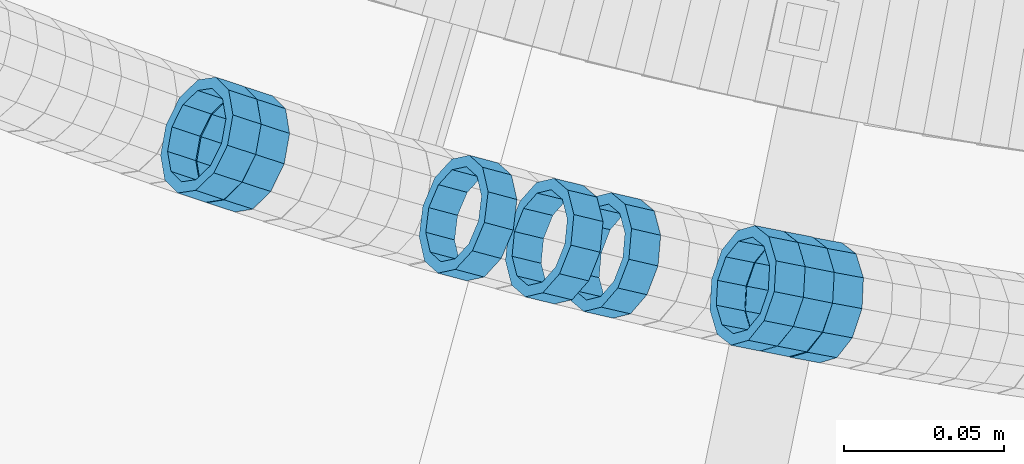
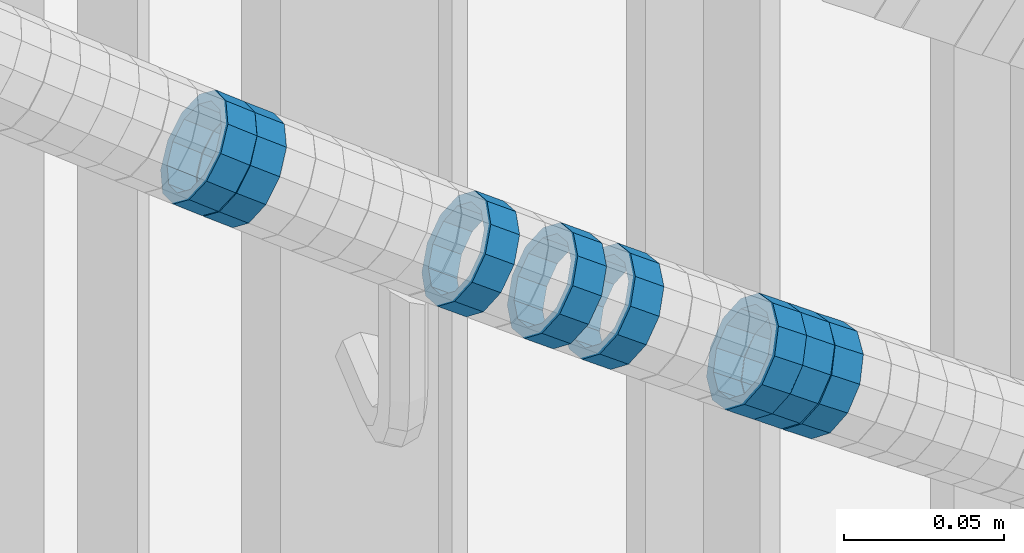
# One storey, part 687 of 975: 8 members.
"""IFC2X3 building model written with IfcOpenShell, lengths in millimetres."""

from ifc_helpers import new_model, si_unit, frame, origin_with_axes, place, context, subcontext, project, spatial, faceted_brep, material, type_object, element, save


model = new_model("IFC2X3")

# Units and contexts
model_context = context("Model", 3, precision=1e-05, world=origin_with_axes())
body_context = subcontext(model_context, "Body", "Model", "MODEL_VIEW")
ifc_project = project(units=[si_unit("LENGTHUNIT", "METRE", prefix="MILLI"), si_unit("AREAUNIT", "SQUARE_METRE"), si_unit("VOLUMEUNIT", "CUBIC_METRE"), si_unit("MASSUNIT", "GRAM", prefix="KILO"), si_unit("TIMEUNIT", "SECOND"), si_unit("PLANEANGLEUNIT", "RADIAN"), si_unit("SOLIDANGLEUNIT", "STERADIAN"), si_unit("THERMODYNAMICTEMPERATUREUNIT", "DEGREE_CELSIUS"), si_unit("LUMINOUSINTENSITYUNIT", "LUMEN")], contexts=[model_context])

# Site, building, storey
site_placement = place(None, origin_with_axes())
site = spatial("IfcSite", under=ifc_project, at=site_placement, CompositionType="ELEMENT")
building_placement = place(site_placement, origin_with_axes())
building = spatial("IfcBuilding", under=site, at=building_placement, Name="Undefined", CompositionType="ELEMENT")
storey_placement = place(building_placement, origin_with_axes())
storey = spatial("IfcBuildingStorey", under=building, at=storey_placement, Name="Undefined", CompositionType="ELEMENT", Elevation=0.0)

# Members
ifc_material = material()
member_type = type_object("IfcMemberType", PredefinedType="NOTDEFINED")
member_1_placement = place(storey_placement, frame((34392.6036302114, 1964.06731073057, 4419.71689974134), z_axis=(-0.224859506573637, -0.974391195723494, -2.19394678424578e-10), x_axis=(-0.827751730694974, 0.191019629929637, 0.527578025805681)))
element("IfcMember", 1, at=member_1_placement, inside=storey, type_object=member_type, material=ifc_material, Name="WALL", context=body_context, shape_type="Brep", body=[
    faceted_brep([(-2.1246523829177e-07, -15.367000000002, 0.0), (-1.83998054126278e-07, -13.3082123799541, 7.68350000000009), (10.9927248669192, -13.3082123799686, 7.6835000000026), (10.9927248668937, -15.3670000000238, 5.6843418860808e-12), (-1.06232619145885e-07, -7.68349999999919, 13.3082123799559), (10.9927248669374, -7.68350000000282, 13.3082123799563), (-3.63797880709171e-12, 3.63797880709171e-12, 15.3670000000002), (10.9927248669519, 0.0, 15.3669999999991), (1.06225343188271e-07, 7.68350000000646, 13.3082123799559), (10.9927248669519, 7.68349999999919, 13.3082123799541), (1.8399441614747e-07, 13.308212379965, 7.68350000000009), (10.9927248669446, 13.3082123799504, 7.68349999999964), (2.12461600312963e-07, 15.3670000000093, 0.0), (10.9927248669301, 15.3669999999838, 1.13686837721616e-12), (1.8399441614747e-07, 13.308212379965, -7.68350000000009), (10.9927248669046, 13.3082123799322, -7.68349999999646), (1.06225343188271e-07, 7.68350000000646, -13.3082123799559), (10.9927248668791, 7.68349999996281, -13.3082123799493), (-3.63797880709171e-12, 3.63797880709171e-12, -15.3670000000002), (10.9927248668719, -3.63797880709171e-11, -15.366999999992), (-1.06232619145885e-07, -7.68349999999919, -13.3082123799559), (10.9927248668682, -7.68350000003193, -13.3082123799472), (-1.83998054126278e-07, -13.3082123799541, -7.68350000000009), (10.9927248668791, -13.3082123799832, -7.68349999999282), (-2.63386027654633e-07, -19.0500000000029, 0.0), (-2.28097633225843e-07, -16.4977839420972, -9.52499999999964), (10.9927248668682, -16.4977839421263, -9.52499999999168), (10.9927248668901, -19.0500000000211, 5.6843418860808e-12), (-1.31691194837913e-07, -9.52500000000146, -16.4977839420935), (10.9927248668573, -9.52500000003783, -16.4977839420844), (-3.63797880709171e-12, 3.63797880709171e-12, -19.0500000000002), (10.992724866861, -4.36557456851006e-11, -19.0499999999909), (1.31687556859106e-07, 9.52500000000509, -16.4977839420935), (10.9927248668755, 9.52499999996144, -16.4977839420865), (2.28097633225843e-07, 16.4977839421044, -9.52499999999964), (10.9927248669046, 16.4977839420644, -9.52499999999577), (2.63382389675826e-07, 19.0500000000138, 0.0), (10.9927248669301, 19.0499999999884, 9.09494701772928e-13), (2.28097633225843e-07, 16.4977839421044, 9.52499999999964), (10.9927248669519, 16.4977839420899, 9.52499999999873), (1.31687556859106e-07, 9.52500000000509, 16.4977839420935), (10.9927248669628, 9.52500000000146, 16.497783942091), (-3.63797880709171e-12, 3.63797880709171e-12, 19.0500000000002), (10.9927248669628, 3.63797880709171e-12, 19.0499999999979), (-1.31691194837913e-07, -9.52500000000146, 16.4977839420935), (10.992724866941, -9.52499999999782, 16.4977839420935), (-2.28097633225843e-07, -16.4977839420972, 9.52499999999964), (10.9927248669192, -16.4977839421008, 9.52500000000282)], [[[0, 1, 2, 3]], [[1, 4, 5, 2]], [[4, 6, 7, 5]], [[6, 8, 9, 7]], [[8, 10, 11, 9]], [[10, 12, 13, 11]], [[12, 14, 15, 13]], [[14, 16, 17, 15]], [[16, 18, 19, 17]], [[18, 20, 21, 19]], [[20, 22, 23, 21]], [[22, 0, 3, 23]], [[24, 25, 26, 27]], [[25, 28, 29, 26]], [[28, 30, 31, 29]], [[30, 32, 33, 31]], [[32, 34, 35, 33]], [[34, 36, 37, 35]], [[36, 38, 39, 37]], [[38, 40, 41, 39]], [[40, 42, 43, 41]], [[42, 44, 45, 43]], [[44, 46, 47, 45]], [[46, 24, 27, 47]], [[29, 31, 33, 35, 37, 39, 41, 43, 45, 47, 27, 26], [5, 7, 9, 11, 13, 15, 17, 19, 21, 23, 3, 2]], [[46, 44, 42, 40, 38, 36, 34, 32, 30, 28, 25, 24], [22, 20, 18, 16, 14, 12, 10, 8, 6, 4, 1, 0]]]),
])
member_2_placement = place(storey_placement, frame((34456.3500308228, 1950.30839046618, 4379.53153296901), z_axis=(-0.181706497129388, -0.983352809982749, 7.94279912952334e-11), x_axis=(-0.839771276762341, 0.155175126956075, 0.520293073852721)))
element("IfcMember", 2, at=member_2_placement, inside=storey, type_object=member_type, material=ifc_material, Name="WALL", context=body_context, shape_type="Brep", body=[
    faceted_brep([(-2.1246523829177e-07, -15.367000000002, 0.0), (-1.83998054126278e-07, -13.3082123799541, 7.68350000000009), (10.9608393839299, -13.3082123799613, 7.68350000000282), (10.9608393839189, -15.3670000000093, 3.63797880709171e-12), (-1.06232619145885e-07, -7.68349999999919, 13.3082123799559), (10.9608393839408, -7.68349999999919, 13.3082123799563), (-3.63797880709171e-12, 3.63797880709171e-12, 15.3670000000002), (10.9608393839517, 3.63797880709171e-12, 15.3669999999993), (1.06225343188271e-07, 7.68350000000646, 13.3082123799559), (10.960839383959, 7.68350000000282, 13.3082123799536), (1.8399441614747e-07, 13.308212379965, 7.68350000000009), (10.9608393839553, 13.3082123799577, 7.68349999999782), (2.12461600312963e-07, 15.3670000000093, 0.0), (10.960839383959, 15.367000000002, -2.27373675443232e-12), (1.8399441614747e-07, 13.308212379965, -7.68350000000009), (10.960839383948, 13.3082123799468, -7.68350000000146), (1.06225343188271e-07, 7.68350000000646, -13.3082123799559), (10.9608393839408, 7.68349999998827, -13.3082123799563), (-3.63797880709171e-12, 3.63797880709171e-12, -15.3670000000002), (10.9608393839299, -1.09139364212751e-11, -15.3669999999993), (-1.06232619145885e-07, -7.68349999999919, -13.3082123799559), (10.9608393839226, -7.68350000001374, -13.3082123799531), (-1.83998054126278e-07, -13.3082123799541, -7.68350000000009), (10.9608393839226, -13.308212379965, -7.68349999999691), (-2.63386027654633e-07, -19.0500000000029, 0.0), (-2.28097633225843e-07, -16.4977839420972, -9.52499999999964), (10.9608393839153, -16.4977839421081, -9.52499999999645), (10.9608393839153, -19.0500000000065, 4.09272615797818e-12), (-1.31691194837913e-07, -9.52500000000146, -16.4977839420935), (10.9608393839189, -9.52500000001237, -16.4977839420908), (-3.63797880709171e-12, 3.63797880709171e-12, -19.0500000000002), (10.9608393839262, -1.45519152283669e-11, -19.0499999999984), (1.31687556859106e-07, 9.52500000000509, -16.4977839420935), (10.9608393839371, 9.5249999999869, -16.4977839420935), (2.28097633225843e-07, 16.4977839421044, -9.52499999999964), (10.9608393839553, 16.4977839420899, -9.52500000000282), (2.63382389675826e-07, 19.0500000000138, 0.0), (10.9608393839626, 19.0499999999993, -3.18323145620525e-12), (2.28097633225843e-07, 16.4977839421044, 9.52499999999964), (10.9608393839626, 16.4977839420972, 9.52499999999645), (1.31687556859106e-07, 9.52500000000509, 16.4977839420935), (10.960839383959, 9.52500000000509, 16.4977839420917), (-3.63797880709171e-12, 3.63797880709171e-12, 19.0500000000002), (10.9608393839517, 7.27595761418343e-12, 19.0499999999997), (-1.31691194837913e-07, -9.52500000000146, 16.4977839420935), (10.9608393839408, -9.52499999999782, 16.4977839420944), (-2.28097633225843e-07, -16.4977839420972, 9.52499999999964), (10.9608393839226, -16.4977839420972, 9.52500000000418)], [[[0, 1, 2, 3]], [[1, 4, 5, 2]], [[4, 6, 7, 5]], [[6, 8, 9, 7]], [[8, 10, 11, 9]], [[10, 12, 13, 11]], [[12, 14, 15, 13]], [[14, 16, 17, 15]], [[16, 18, 19, 17]], [[18, 20, 21, 19]], [[20, 22, 23, 21]], [[22, 0, 3, 23]], [[24, 25, 26, 27]], [[25, 28, 29, 26]], [[28, 30, 31, 29]], [[30, 32, 33, 31]], [[32, 34, 35, 33]], [[34, 36, 37, 35]], [[36, 38, 39, 37]], [[38, 40, 41, 39]], [[40, 42, 43, 41]], [[42, 44, 45, 43]], [[44, 46, 47, 45]], [[46, 24, 27, 47]], [[29, 31, 33, 35, 37, 39, 41, 43, 45, 47, 27, 26], [5, 7, 9, 11, 13, 15, 17, 19, 21, 23, 3, 2]], [[46, 44, 42, 40, 38, 36, 34, 32, 30, 28, 25, 24], [22, 20, 18, 16, 14, 12, 10, 8, 6, 4, 1, 0]]]),
])
member_3_placement = place(storey_placement, frame((34446.9892070806, 1952.16709826229, 4385.34743555916), z_axis=(-0.194042592250524, -0.980993105170825, 1.32939021568745e-10), x_axis=(-0.831787632890537, 0.164529421978332, 0.530150358930212)))
element("IfcMember", 3, at=member_3_placement, inside=storey, type_object=member_type, material=ifc_material, Name="WALL", context=body_context, shape_type="Brep", body=[
    faceted_brep([(-2.1246523829177e-07, -15.367000000002, 0.0), (-1.83998054126278e-07, -13.3082123799541, 7.68350000000009), (10.9448618081915, -13.3082123799541, 7.68349999999987), (10.944861808206, -15.3669999999875, -1.81898940354586e-12), (-1.06232619145885e-07, -7.68349999999919, 13.3082123799559), (10.9448618081733, -7.68350000000282, 13.3082123799568), (-3.63797880709171e-12, 3.63797880709171e-12, 15.3670000000002), (10.944861808166, -1.09139364212751e-11, 15.3670000000025), (1.06225343188271e-07, 7.68350000000646, 13.3082123799559), (10.9448618081624, 7.68349999998827, 13.3082123799586), (1.8399441614747e-07, 13.308212379965, 7.68350000000009), (10.9448618081697, 13.3082123799468, 7.68350000000214), (2.12461600312963e-07, 15.3670000000093, 0.0), (10.9448618081842, 15.3669999999984, 2.27373675443232e-13), (1.8399441614747e-07, 13.308212379965, -7.68350000000009), (10.9448618082024, 13.3082123799613, -7.68350000000123), (1.06225343188271e-07, 7.68350000000646, -13.3082123799559), (10.944861808217, 7.68350000001374, -13.3082123799586), (-3.63797880709171e-12, 3.63797880709171e-12, -15.3670000000002), (10.9448618082242, 1.45519152283669e-11, -15.3670000000036), (-1.06232619145885e-07, -7.68349999999919, -13.3082123799559), (10.9448618082279, -7.68349999997736, -13.30821237996), (-1.83998054126278e-07, -13.3082123799541, -7.68350000000009), (10.9448618082242, -13.3082123799322, -7.68350000000351), (-2.63386027654633e-07, -19.0500000000029, 0.0), (-2.28097633225843e-07, -16.4977839420972, -9.52499999999964), (10.9448618082242, -16.4977839420681, -9.52500000000418), (10.9448618082097, -19.0499999999847, -2.50111042987555e-12), (-1.31691194837913e-07, -9.52500000000146, -16.4977839420935), (10.9448618082351, -9.52499999997599, -16.4977839420985), (-3.63797880709171e-12, 3.63797880709171e-12, -19.0500000000002), (10.9448618082315, 2.5465851649642e-11, -19.050000000004), (1.31687556859106e-07, 9.52500000000509, -16.4977839420935), (10.9448618082242, 9.52500000001601, -16.4977839420967), (2.28097633225843e-07, 16.4977839421044, -9.52499999999964), (10.9448618082097, 16.4977839421008, -9.52500000000146), (2.63382389675826e-07, 19.0500000000138, 0.0), (10.9448618081842, 19.049999999992, 1.13686837721616e-12), (2.28097633225843e-07, 16.4977839421044, 9.52499999999964), (10.944861808166, 16.4977839420826, 9.52500000000259), (1.31687556859106e-07, 9.52500000000509, 16.4977839420935), (10.9448618081624, 9.52499999998327, 16.4977839420972), (-3.63797880709171e-12, 3.63797880709171e-12, 19.0500000000002), (10.9448618081587, -1.09139364212751e-11, 19.0500000000031), (-1.31691194837913e-07, -9.52500000000146, 16.4977839420935), (10.9448618081697, -9.52500000000873, 16.4977839420953), (-2.28097633225843e-07, -16.4977839420972, 9.52499999999964), (10.9448618081915, -16.4977839420899, 9.52499999999941)], [[[0, 1, 2, 3]], [[1, 4, 5, 2]], [[4, 6, 7, 5]], [[6, 8, 9, 7]], [[8, 10, 11, 9]], [[10, 12, 13, 11]], [[12, 14, 15, 13]], [[14, 16, 17, 15]], [[16, 18, 19, 17]], [[18, 20, 21, 19]], [[20, 22, 23, 21]], [[22, 0, 3, 23]], [[24, 25, 26, 27]], [[25, 28, 29, 26]], [[28, 30, 31, 29]], [[30, 32, 33, 31]], [[32, 34, 35, 33]], [[34, 36, 37, 35]], [[36, 38, 39, 37]], [[38, 40, 41, 39]], [[40, 42, 43, 41]], [[42, 44, 45, 43]], [[44, 46, 47, 45]], [[46, 24, 27, 47]], [[29, 31, 33, 35, 37, 39, 41, 43, 45, 47, 27, 26], [5, 7, 9, 11, 13, 15, 17, 19, 21, 23, 3, 2]], [[46, 44, 42, 40, 38, 36, 34, 32, 30, 28, 25, 24], [22, 20, 18, 16, 14, 12, 10, 8, 6, 4, 1, 0]]]),
])
member_4_placement = place(storey_placement, frame((34374.5450132188, 1968.46492125248, 4431.20583944636), z_axis=(-0.234988560617363, -0.97199813599563, 3.72391696146223e-10), x_axis=(-0.826283145822644, 0.199760760957095, 0.526642004886884)))
element("IfcMember", 4, at=member_4_placement, inside=storey, type_object=member_type, material=ifc_material, Name="WALL", context=body_context, shape_type="Brep", body=[
    faceted_brep([(-2.1246523829177e-07, -15.367000000002, 0.0), (-1.83998054126278e-07, -13.3082123799541, 7.68350000000009), (11.011811840086, -13.308212379925, 7.683499999981), (11.0118118400642, -15.3669999999838, -9.09494701772928e-12), (-1.06232619145885e-07, -7.68349999999919, 13.3082123799559), (11.0118118400896, -7.68349999997008, 13.3082123799377), (-3.63797880709171e-12, 3.63797880709171e-12, 15.3670000000002), (11.0118118400751, 2.5465851649642e-11, 15.3669999999875), (1.06225343188271e-07, 7.68350000000646, 13.3082123799559), (11.0118118400496, 7.6835000000101, 13.3082123799504), (1.8399441614747e-07, 13.308212379965, 7.68350000000009), (11.0118118400242, 13.3082123799504, 7.68350000000646), (2.12461600312963e-07, 15.3670000000093, 0.0), (11.0118118399951, 15.3669999999765, 1.63709046319127e-11), (1.8399441614747e-07, 13.308212379965, -7.68350000000009), (11.0118118399769, 13.3082123799213, -7.68349999997736), (1.06225343188271e-07, 7.68350000000646, -13.3082123799559), (11.0118118399769, 7.68349999996644, -13.3082123799322), (-3.63797880709171e-12, 3.63797880709171e-12, -15.3670000000002), (11.0118118399841, -2.5465851649642e-11, -15.366999999982), (-1.06232619145885e-07, -7.68349999999919, -13.3082123799559), (11.011811840006, -7.68350000001737, -13.308212379945), (-1.83998054126278e-07, -13.3082123799541, -7.68350000000009), (11.0118118400424, -13.3082123799541, -7.683500000001), (-2.63386027654633e-07, -19.0500000000029, 0.0), (-2.28097633225843e-07, -16.4977839420972, -9.52499999999964), (11.0118118400424, -16.4977839420935, -9.52500000000327), (11.0118118400751, -19.0499999999738, -1.63709046319127e-11), (-1.31691194837913e-07, -9.52500000000146, -16.4977839420935), (11.011811840006, -9.52500000001601, -16.4977839420826), (-3.63797880709171e-12, 3.63797880709171e-12, -19.0500000000002), (11.0118118399732, -3.27418092638254e-11, -19.0499999999793), (1.31687556859106e-07, 9.52500000000509, -16.4977839420935), (11.0118118399623, 9.5249999999578, -16.4977839420662), (2.28097633225843e-07, 16.4977839421044, -9.52499999999964), (11.0118118399623, 16.4977839420535, -9.52499999997235), (2.63382389675826e-07, 19.0500000000138, 0.0), (11.0118118399878, 19.0499999999738, 1.81898940354586e-11), (2.28097633225843e-07, 16.4977839421044, 9.52499999999964), (11.0118118400169, 16.4977839420862, 9.52500000000691), (1.31687556859106e-07, 9.52500000000509, 16.4977839420935), (11.0118118400569, 9.52500000001601, 16.4977839420862), (-3.63797880709171e-12, 3.63797880709171e-12, 19.0500000000002), (11.011811840086, 3.63797880709171e-11, 19.0499999999811), (-1.31691194837913e-07, -9.52500000000146, 16.4977839420935), (11.0118118401006, -9.5249999999578, 16.4977839420681), (-2.28097633225843e-07, -16.4977839420972, 9.52499999999964), (11.0118118400933, -16.4977839420608, 9.52499999997781)], [[[0, 1, 2, 3]], [[1, 4, 5, 2]], [[4, 6, 7, 5]], [[6, 8, 9, 7]], [[8, 10, 11, 9]], [[10, 12, 13, 11]], [[12, 14, 15, 13]], [[14, 16, 17, 15]], [[16, 18, 19, 17]], [[18, 20, 21, 19]], [[20, 22, 23, 21]], [[22, 0, 3, 23]], [[24, 25, 26, 27]], [[25, 28, 29, 26]], [[28, 30, 31, 29]], [[30, 32, 33, 31]], [[32, 34, 35, 33]], [[34, 36, 37, 35]], [[36, 38, 39, 37]], [[38, 40, 41, 39]], [[40, 42, 43, 41]], [[42, 44, 45, 43]], [[44, 46, 47, 45]], [[46, 24, 27, 47]], [[29, 31, 33, 35, 37, 39, 41, 43, 45, 47, 27, 26], [5, 7, 9, 11, 13, 15, 17, 19, 21, 23, 3, 2]], [[46, 44, 42, 40, 38, 36, 34, 32, 30, 28, 25, 24], [22, 20, 18, 16, 14, 12, 10, 8, 6, 4, 1, 0]]]),
])
member_5_placement = place(storey_placement, frame((34438.0129093216, 1953.94262968713, 4391.06927369576), z_axis=(-0.194042592250524, -0.980993105170825, 1.32939021568745e-10), x_axis=(-0.835812632560148, 0.165325575913002, 0.523530989724495)))
element("IfcMember", 5, at=member_5_placement, inside=storey, type_object=member_type, material=ifc_material, Name="WALL", context=body_context, shape_type="Brep", body=[
    faceted_brep([(-2.1246523829177e-07, -15.367000000002, 0.0), (-1.83998054126278e-07, -13.3082123799541, 7.68350000000009), (10.8908218239267, -13.3082123799468, 7.68349999999828), (10.8908218239521, -15.3669999999729, -6.3664629124105e-12), (-1.06232619145885e-07, -7.68349999999919, 13.3082123799559), (10.8908218238939, -7.6835000000101, 13.3082123799586), (-3.63797880709171e-12, 3.63797880709171e-12, 15.3670000000002), (10.8908218238757, -2.18278728425503e-11, 15.3670000000075), (1.06225343188271e-07, 7.68350000000646, 13.3082123799559), (10.8908218238612, 7.68349999996644, 13.308212379965), (1.8399441614747e-07, 13.308212379965, 7.68350000000009), (10.8908218238612, 13.308212379925, 7.68350000000919), (2.12461600312963e-07, 15.3670000000093, 0.0), (10.8908218238794, 15.3669999999802, 5.45696821063757e-12), (1.8399441614747e-07, 13.308212379965, -7.68350000000009), (10.8908218239012, 13.3082123799541, -7.68349999999828), (1.06225343188271e-07, 7.68350000000646, -13.3082123799559), (10.8908218239339, 7.68350000001737, -13.30821237996), (-3.63797880709171e-12, 3.63797880709171e-12, -15.3670000000002), (10.8908218239558, 3.27418092638254e-11, -15.3670000000075), (-1.06232619145885e-07, -7.68349999999919, -13.3082123799559), (10.890821823974, -7.68349999996281, -13.308212379965), (-1.83998054126278e-07, -13.3082123799541, -7.68350000000009), (10.8908218239667, -13.3082123799177, -7.68350000000919), (-2.63386027654633e-07, -19.0500000000029, 0.0), (-2.28097633225843e-07, -16.4977839420972, -9.52499999999964), (10.8908218239812, -16.4977839420499, -9.52500000001055), (10.8908218239594, -19.0499999999665, -7.73070496506989e-12), (-1.31691194837913e-07, -9.52500000000146, -16.4977839420935), (10.8908218239812, -9.52499999994689, -16.4977839421063), (-3.63797880709171e-12, 3.63797880709171e-12, -19.0500000000002), (10.8908218239703, 3.63797880709171e-11, -19.0500000000093), (1.31687556859106e-07, 9.52500000000509, -16.4977839420935), (10.8908218239412, 9.52500000002328, -16.4977839420981), (2.28097633225843e-07, 16.4977839421044, -9.52499999999964), (10.8908218239048, 16.4977839420899, -9.52499999999873), (2.63382389675826e-07, 19.0500000000138, 0.0), (10.8908218238685, 19.0499999999774, 6.82121026329696e-12), (2.28097633225843e-07, 16.4977839421044, 9.52499999999964), (10.8908218238539, 16.4977839420535, 9.525000000011), (1.31687556859106e-07, 9.52500000000509, 16.4977839420935), (10.8908218238466, 9.52499999996144, 16.4977839421058), (-3.63797880709171e-12, 3.63797880709171e-12, 19.0500000000002), (10.8908218238648, -3.27418092638254e-11, 19.0500000000097), (-1.31691194837913e-07, -9.52500000000146, 16.4977839420935), (10.8908218238939, -9.52500000000873, 16.4977839420972), (-2.28097633225843e-07, -16.4977839420972, 9.52499999999964), (10.8908218239267, -16.4977839420826, 9.52499999999873)], [[[0, 1, 2, 3]], [[1, 4, 5, 2]], [[4, 6, 7, 5]], [[6, 8, 9, 7]], [[8, 10, 11, 9]], [[10, 12, 13, 11]], [[12, 14, 15, 13]], [[14, 16, 17, 15]], [[16, 18, 19, 17]], [[18, 20, 21, 19]], [[20, 22, 23, 21]], [[22, 0, 3, 23]], [[24, 25, 26, 27]], [[25, 28, 29, 26]], [[28, 30, 31, 29]], [[30, 32, 33, 31]], [[32, 34, 35, 33]], [[34, 36, 37, 35]], [[36, 38, 39, 37]], [[38, 40, 41, 39]], [[40, 42, 43, 41]], [[42, 44, 45, 43]], [[44, 46, 47, 45]], [[46, 24, 27, 47]], [[29, 31, 33, 35, 37, 39, 41, 43, 45, 47, 27, 26], [5, 7, 9, 11, 13, 15, 17, 19, 21, 23, 3, 2]], [[46, 44, 42, 40, 38, 36, 34, 32, 30, 28, 25, 24], [22, 20, 18, 16, 14, 12, 10, 8, 6, 4, 1, 0]]]),
])
member_6_placement = place(storey_placement, frame((34347.5888265773, 1975.56946803607, 4448.45104049629), z_axis=(-0.257662650594451, -0.966234939592148, -1.78564732777886e-10), x_axis=(-0.824163383850657, 0.219776901960162, 0.521970142905347)))
element("IfcMember", 6, at=member_6_placement, inside=storey, type_object=member_type, material=ifc_material, Name="WALL", context=body_context, shape_type="Brep", body=[
    faceted_brep([(-2.1246523829177e-07, -15.367000000002, 0.0), (-1.83998054126278e-07, -13.3082123799541, 7.68350000000009), (10.9242848735521, -13.3082123800159, 7.68350000000919), (10.9242848735703, -15.3670000000457, 6.82121026329696e-12), (-1.06232619145885e-07, -7.68349999999919, 13.3082123799559), (10.9242848735521, -7.68350000005739, 13.3082123799652), (-3.63797880709171e-12, 3.63797880709171e-12, 15.3670000000002), (10.924284873563, -4.72937244921923e-11, 15.3670000000088), (1.06225343188271e-07, 7.68350000000646, 13.3082123799559), (10.9242848735885, 7.68349999997008, 13.308212379962), (1.8399441614747e-07, 13.308212379965, 7.68350000000009), (10.9242848736176, 13.3082123799468, 7.68350000000328), (2.12461600312963e-07, 15.3670000000093, 0.0), (10.9242848736394, 15.3670000000093, 0.0), (1.8399441614747e-07, 13.308212379965, -7.68350000000009), (10.9242848736576, 13.3082123799795, -7.6835000000026), (1.06225343188271e-07, 7.68350000000646, -13.3082123799559), (10.9242848736576, 7.68350000002465, -13.3082123799584), (-3.63797880709171e-12, 3.63797880709171e-12, -15.3670000000002), (10.9242848736467, 1.45519152283669e-11, -15.3670000000025), (-1.06232619145885e-07, -7.68349999999919, -13.3082123799559), (10.9242848736212, -7.68350000000282, -13.3082123799552), (-1.83998054126278e-07, -13.3082123799541, -7.68350000000009), (10.9242848735958, -13.3082123799832, -7.68349999999646), (-2.63386027654633e-07, -19.0500000000029, 0.0), (-2.28097633225843e-07, -16.4977839420972, -9.52499999999964), (10.9242848735885, -16.4977839421226, -9.52499999999577), (10.9242848735557, -19.0500000000575, 8.18545231595635e-12), (-1.31691194837913e-07, -9.52500000000146, -16.4977839420935), (10.9242848736249, -9.52500000000146, -16.4977839420942), (-3.63797880709171e-12, 3.63797880709171e-12, -19.0500000000002), (10.924284873654, 2.18278728425503e-11, -19.0500000000038), (1.31687556859106e-07, 9.52500000000509, -16.4977839420935), (10.9242848736758, 9.52500000003783, -16.4977839420985), (2.28097633225843e-07, 16.4977839421044, -9.52499999999964), (10.9242848736758, 16.4977839421299, -9.52500000000418), (2.63382389675826e-07, 19.0500000000138, 0.0), (10.9242848736503, 19.0500000000211, -1.36424205265939e-12), (2.28097633225843e-07, 16.4977839421044, 9.52499999999964), (10.9242848736249, 16.4977839420899, 9.52500000000259), (1.31687556859106e-07, 9.52500000000509, 16.4977839420935), (10.9242848735885, 9.52499999996508, 16.4977839421008), (-3.63797880709171e-12, 3.63797880709171e-12, 19.0500000000002), (10.9242848735594, -5.82076609134674e-11, 19.0500000000104), (-1.31691194837913e-07, -9.52500000000146, 16.4977839420935), (10.9242848735375, -9.52500000007058, 16.4977839421056), (-2.28097633225843e-07, -16.4977839420972, 9.52499999999964), (10.9242848735412, -16.4977839421626, 9.52500000001078)], [[[0, 1, 2, 3]], [[1, 4, 5, 2]], [[4, 6, 7, 5]], [[6, 8, 9, 7]], [[8, 10, 11, 9]], [[10, 12, 13, 11]], [[12, 14, 15, 13]], [[14, 16, 17, 15]], [[16, 18, 19, 17]], [[18, 20, 21, 19]], [[20, 22, 23, 21]], [[22, 0, 3, 23]], [[24, 25, 26, 27]], [[25, 28, 29, 26]], [[28, 30, 31, 29]], [[30, 32, 33, 31]], [[32, 34, 35, 33]], [[34, 36, 37, 35]], [[36, 38, 39, 37]], [[38, 40, 41, 39]], [[40, 42, 43, 41]], [[42, 44, 45, 43]], [[44, 46, 47, 45]], [[46, 24, 27, 47]], [[29, 31, 33, 35, 37, 39, 41, 43, 45, 47, 27, 26], [5, 7, 9, 11, 13, 15, 17, 19, 21, 23, 3, 2]], [[46, 44, 42, 40, 38, 36, 34, 32, 30, 28, 25, 24], [22, 20, 18, 16, 14, 12, 10, 8, 6, 4, 1, 0]]]),
])
member_7_placement = place(storey_placement, frame((34276.2762292559, 1996.77695495048, 4494.32927070918), z_axis=(-0.309810671656531, -0.950798268681496, -1.38775249070022e-10), x_axis=(-0.812083007662321, 0.264611316889997, 0.520098105783765)))
element("IfcMember", 7, at=member_7_placement, inside=storey, type_object=member_type, material=ifc_material, Name="WALL", context=body_context, shape_type="Brep", body=[
    faceted_brep([(-2.1246523829177e-07, -15.367000000002, 0.0), (-1.83998054126278e-07, -13.3082123799541, 7.68350000000009), (10.9608393839299, -13.3082123799613, 7.68350000000282), (10.9608393839189, -15.3670000000093, 3.63797880709171e-12), (-1.06232619145885e-07, -7.68349999999919, 13.3082123799559), (10.9608393839408, -7.68349999999919, 13.3082123799563), (-3.63797880709171e-12, 3.63797880709171e-12, 15.3670000000002), (10.9608393839517, 3.63797880709171e-12, 15.3669999999993), (1.06225343188271e-07, 7.68350000000646, 13.3082123799559), (10.960839383959, 7.68350000000282, 13.3082123799536), (1.8399441614747e-07, 13.308212379965, 7.68350000000009), (10.9608393839553, 13.3082123799577, 7.68349999999782), (2.12461600312963e-07, 15.3670000000093, 0.0), (10.960839383959, 15.367000000002, -2.27373675443232e-12), (1.8399441614747e-07, 13.308212379965, -7.68350000000009), (10.960839383948, 13.3082123799468, -7.68350000000146), (1.06225343188271e-07, 7.68350000000646, -13.3082123799559), (10.9608393839408, 7.68349999998827, -13.3082123799563), (-3.63797880709171e-12, 3.63797880709171e-12, -15.3670000000002), (10.9608393839299, -1.09139364212751e-11, -15.3669999999993), (-1.06232619145885e-07, -7.68349999999919, -13.3082123799559), (10.9608393839226, -7.68350000001374, -13.3082123799531), (-1.83998054126278e-07, -13.3082123799541, -7.68350000000009), (10.9608393839226, -13.308212379965, -7.68349999999691), (-2.63386027654633e-07, -19.0500000000029, 0.0), (-2.28097633225843e-07, -16.4977839420972, -9.52499999999964), (10.9608393839153, -16.4977839421081, -9.52499999999645), (10.9608393839153, -19.0500000000065, 4.09272615797818e-12), (-1.31691194837913e-07, -9.52500000000146, -16.4977839420935), (10.9608393839189, -9.52500000001237, -16.4977839420908), (-3.63797880709171e-12, 3.63797880709171e-12, -19.0500000000002), (10.9608393839262, -1.45519152283669e-11, -19.0499999999984), (1.31687556859106e-07, 9.52500000000509, -16.4977839420935), (10.9608393839371, 9.5249999999869, -16.4977839420935), (2.28097633225843e-07, 16.4977839421044, -9.52499999999964), (10.9608393839553, 16.4977839420899, -9.52500000000282), (2.63382389675826e-07, 19.0500000000138, 0.0), (10.9608393839626, 19.0499999999993, -3.18323145620525e-12), (2.28097633225843e-07, 16.4977839421044, 9.52499999999964), (10.9608393839626, 16.4977839420972, 9.52499999999645), (1.31687556859106e-07, 9.52500000000509, 16.4977839420935), (10.960839383959, 9.52500000000509, 16.4977839420917), (-3.63797880709171e-12, 3.63797880709171e-12, 19.0500000000002), (10.9608393839517, 7.27595761418343e-12, 19.0499999999997), (-1.31691194837913e-07, -9.52500000000146, 16.4977839420935), (10.9608393839408, -9.52499999999782, 16.4977839420944), (-2.28097633225843e-07, -16.4977839420972, 9.52499999999964), (10.9608393839226, -16.4977839420972, 9.52500000000418)], [[[0, 1, 2, 3]], [[1, 4, 5, 2]], [[4, 6, 7, 5]], [[6, 8, 9, 7]], [[8, 10, 11, 9]], [[10, 12, 13, 11]], [[12, 14, 15, 13]], [[14, 16, 17, 15]], [[16, 18, 19, 17]], [[18, 20, 21, 19]], [[20, 22, 23, 21]], [[22, 0, 3, 23]], [[24, 25, 26, 27]], [[25, 28, 29, 26]], [[28, 30, 31, 29]], [[30, 32, 33, 31]], [[32, 34, 35, 33]], [[34, 36, 37, 35]], [[36, 38, 39, 37]], [[38, 40, 41, 39]], [[40, 42, 43, 41]], [[42, 44, 45, 43]], [[44, 46, 47, 45]], [[46, 24, 27, 47]], [[29, 31, 33, 35, 37, 39, 41, 43, 45, 47, 27, 26], [5, 7, 9, 11, 13, 15, 17, 19, 21, 23, 3, 2]], [[46, 44, 42, 40, 38, 36, 34, 32, 30, 28, 25, 24], [22, 20, 18, 16, 14, 12, 10, 8, 6, 4, 1, 0]]]),
])
member_8_placement = place(storey_placement, frame((34267.1966474159, 1999.77101673326, 4500.15272105982), z_axis=(-0.312988116355664, -0.949757042100838, 1.91695107787382e-10), x_axis=(-0.805038947060024, 0.265296926019765, 0.530593851039523)))
element("IfcMember", 8, at=member_8_placement, inside=storey, type_object=member_type, material=ifc_material, Name="WALL", context=body_context, shape_type="Brep", body=[
    faceted_brep([(-2.1246523829177e-07, -15.367000000002, 0.0), (-1.83998054126278e-07, -13.3082123799541, 7.68350000000009), (10.9334349588862, -13.3082123799722, 7.68350000000555), (10.9334349588862, -15.3670000000166, 5.45696821063757e-12), (-1.06232619145885e-07, -7.68349999999919, 13.3082123799559), (10.9334349588826, -7.68350000001737, 13.3082123799609), (-3.63797880709171e-12, 3.63797880709171e-12, 15.3670000000002), (10.9334349588862, -1.45519152283669e-11, 15.3670000000043), (1.06225343188271e-07, 7.68350000000646, 13.3082123799559), (10.9334349588898, 7.68349999998827, 13.3082123799591), (1.8399441614747e-07, 13.308212379965, 7.68350000000009), (10.9334349588898, 13.3082123799395, 7.68350000000419), (2.12461600312963e-07, 15.3670000000093, 0.0), (10.9334349588971, 15.3669999999911, 3.63797880709171e-12), (1.8399441614747e-07, 13.308212379965, -7.68350000000009), (10.9334349588935, 13.3082123799431, -7.683499999996), (1.06225343188271e-07, 7.68350000000646, -13.3082123799559), (10.9334349588971, 7.68349999998827, -13.3082123799518), (-3.63797880709171e-12, 3.63797880709171e-12, -15.3670000000002), (10.9334349588971, -1.45519152283669e-11, -15.3669999999961), (-1.06232619145885e-07, -7.68349999999919, -13.3082123799559), (10.9334349588935, -7.68350000001737, -13.3082123799509), (-1.83998054126278e-07, -13.3082123799541, -7.68350000000009), (10.9334349588898, -13.3082123799686, -7.68349999999464), (-2.63386027654633e-07, -19.0500000000029, 0.0), (-2.28097633225843e-07, -16.4977839420972, -9.52499999999964), (10.9334349588898, -16.4977839421117, -9.52499999999372), (10.9334349588898, -19.0500000000211, 5.45696821063757e-12), (-1.31691194837913e-07, -9.52500000000146, -16.4977839420935), (10.9334349588971, -9.52500000001237, -16.4977839420885), (-3.63797880709171e-12, 3.63797880709171e-12, -19.0500000000002), (10.9334349588971, -1.09139364212751e-11, -19.0499999999961), (1.31687556859106e-07, 9.52500000000509, -16.4977839420935), (10.9334349589008, 9.52499999999054, -16.4977839420894), (2.28097633225843e-07, 16.4977839421044, -9.52499999999964), (10.9334349589008, 16.4977839420826, -9.52499999999645), (2.63382389675826e-07, 19.0500000000138, 0.0), (10.9334349588898, 19.0499999999884, 3.18323145620525e-12), (2.28097633225843e-07, 16.4977839421044, 9.52499999999964), (10.9334349588935, 16.497783942079, 9.52500000000282), (1.31687556859106e-07, 9.52500000000509, 16.4977839420935), (10.9334349588826, 9.52499999998327, 16.4977839420976), (-3.63797880709171e-12, 3.63797880709171e-12, 19.0500000000002), (10.9334349588826, -1.81898940354586e-11, 19.0500000000043), (-1.31691194837913e-07, -9.52500000000146, 16.4977839420935), (10.9334349588826, -9.52500000001965, 16.4977839420994), (-2.28097633225843e-07, -16.4977839420972, 9.52499999999964), (10.9334349588826, -16.4977839421117, 9.52500000000646)], [[[0, 1, 2, 3]], [[1, 4, 5, 2]], [[4, 6, 7, 5]], [[6, 8, 9, 7]], [[8, 10, 11, 9]], [[10, 12, 13, 11]], [[12, 14, 15, 13]], [[14, 16, 17, 15]], [[16, 18, 19, 17]], [[18, 20, 21, 19]], [[20, 22, 23, 21]], [[22, 0, 3, 23]], [[24, 25, 26, 27]], [[25, 28, 29, 26]], [[28, 30, 31, 29]], [[30, 32, 33, 31]], [[32, 34, 35, 33]], [[34, 36, 37, 35]], [[36, 38, 39, 37]], [[38, 40, 41, 39]], [[40, 42, 43, 41]], [[42, 44, 45, 43]], [[44, 46, 47, 45]], [[46, 24, 27, 47]], [[29, 31, 33, 35, 37, 39, 41, 43, 45, 47, 27, 26], [5, 7, 9, 11, 13, 15, 17, 19, 21, 23, 3, 2]], [[46, 44, 42, 40, 38, 36, 34, 32, 30, 28, 25, 24], [22, 20, 18, 16, 14, 12, 10, 8, 6, 4, 1, 0]]]),
])

save(model, "model.ifc")
